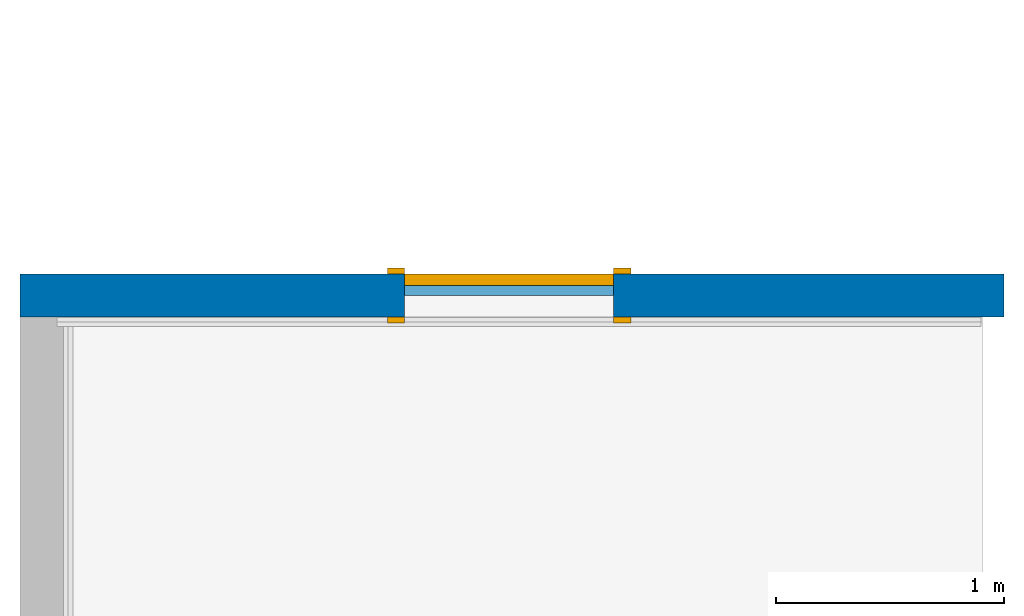
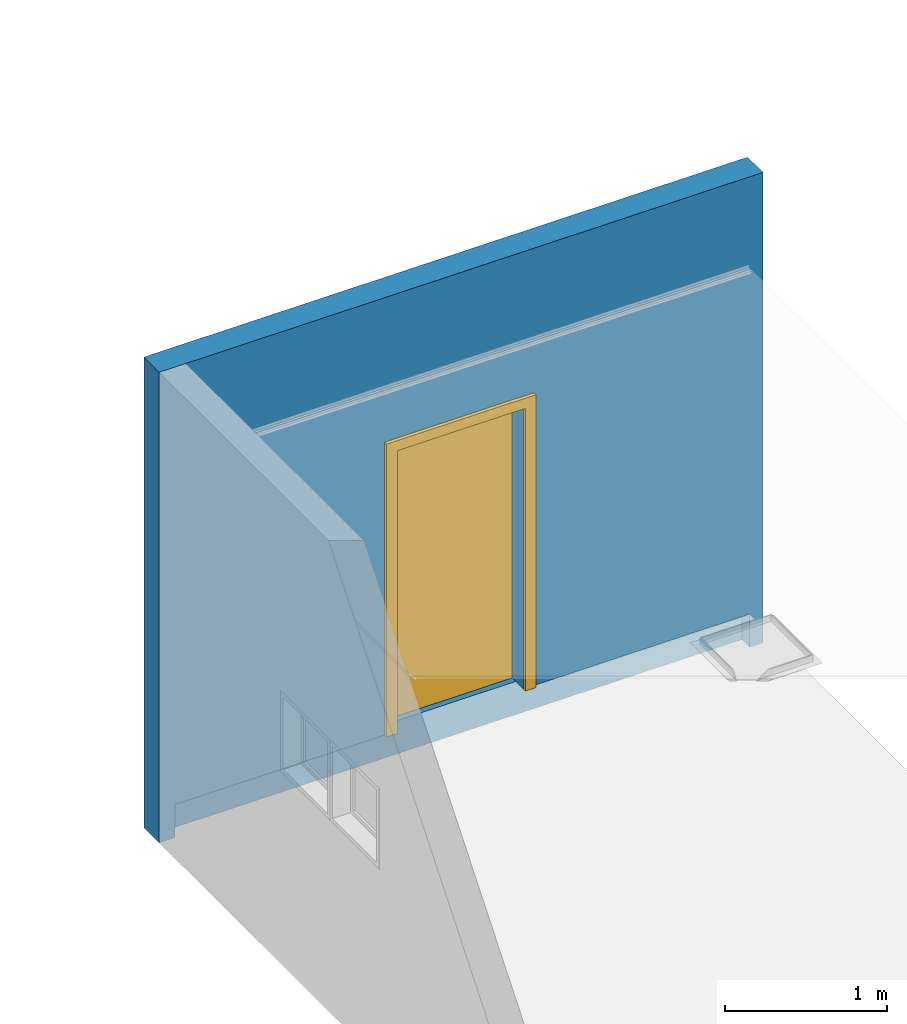
# One storey, part 2 of 5: 1 door, 1 wall, 1 opening.
"""IFC2X3 building model written with IfcOpenShell, lengths in millimetres."""

from ifc_helpers import new_model, entity, si_unit, converted_unit, derived_unit, direction, frame, frame_2d, origin, place, context, subcontext, project, spatial, polyline, rectangle, outline, extrude, faceted_brep, source, transform, mapped, material, material_list, layer, layer_set, type_object, type_shapes, element, fill, save


model = new_model("IFC2X3")

# Units and contexts
model_context = context("Model", 3, precision=0.01, world=origin(), true_north=direction((6.12303176911189e-17, 1.0)))
body_context = subcontext(model_context, "Body", "Model", "MODEL_VIEW")
ifc_project = project(units=[si_unit("LENGTHUNIT", "METRE", prefix="MILLI"), si_unit("AREAUNIT", "SQUARE_METRE"), si_unit("VOLUMEUNIT", "CUBIC_METRE"), converted_unit("PLANEANGLEUNIT", "DEGREE", entity("IfcRatioMeasure", 0.0174532925199433), si_unit("PLANEANGLEUNIT", "RADIAN"), dimensions=[0, 0, 0, 0, 0, 0, 0]), si_unit("MASSUNIT", "GRAM", prefix="KILO"), derived_unit("MASSDENSITYUNIT", [(si_unit("MASSUNIT", "GRAM", prefix="KILO"), 1), (si_unit("LENGTHUNIT", "METRE"), -3)]), si_unit("TIMEUNIT", "SECOND"), si_unit("FREQUENCYUNIT", "HERTZ"), si_unit("THERMODYNAMICTEMPERATUREUNIT", "DEGREE_CELSIUS"), derived_unit("THERMALTRANSMITTANCEUNIT", [(si_unit("MASSUNIT", "GRAM", prefix="KILO"), 1), (si_unit("THERMODYNAMICTEMPERATUREUNIT", "KELVIN"), -1), (si_unit("TIMEUNIT", "SECOND"), -3)]), derived_unit("VOLUMETRICFLOWRATEUNIT", [(si_unit("LENGTHUNIT", "METRE"), 3), (si_unit("TIMEUNIT", "SECOND"), -1)]), si_unit("ELECTRICCURRENTUNIT", "AMPERE"), si_unit("ELECTRICVOLTAGEUNIT", "VOLT"), si_unit("POWERUNIT", "WATT"), si_unit("FORCEUNIT", "NEWTON", prefix="KILO"), si_unit("ILLUMINANCEUNIT", "LUX"), si_unit("LUMINOUSFLUXUNIT", "LUMEN"), si_unit("LUMINOUSINTENSITYUNIT", "CANDELA"), derived_unit("USERDEFINED", [(si_unit("MASSUNIT", "GRAM", prefix="KILO"), -1), (si_unit("LENGTHUNIT", "METRE"), -2), (si_unit("TIMEUNIT", "SECOND"), 3), (si_unit("LUMINOUSFLUXUNIT", "LUMEN"), 1)]), derived_unit("LINEARVELOCITYUNIT", [(si_unit("LENGTHUNIT", "METRE"), 1), (si_unit("TIMEUNIT", "SECOND"), -1)]), si_unit("PRESSUREUNIT", "PASCAL"), derived_unit("USERDEFINED", [(si_unit("LENGTHUNIT", "METRE"), -2), (si_unit("MASSUNIT", "GRAM", prefix="KILO"), 1), (si_unit("TIMEUNIT", "SECOND"), -2)])], contexts=[model_context])

# Site, building, storey
site_placement = place(None, origin())
site = spatial("IfcSite", under=ifc_project, at=site_placement, CompositionType="ELEMENT")
building_placement = place(site_placement, origin())
building = spatial("IfcBuilding", under=site, at=building_placement, CompositionType="ELEMENT")
storey_placement = place(building_placement, origin())
storey = spatial("IfcBuildingStorey", under=building, at=storey_placement, Name="Base Level", CompositionType="ELEMENT", Elevation=0.0)

# Wall, opening, door
ifc_material_1 = material(Name="np_Plastered")
ifc_layer = layer(ifc_material_1, 190.0)
ifc_layer_set = layer_set([ifc_layer], Name="Basic Wall:190mm BLOCK- plastered")
wall_type = type_object("IfcWallType", Name="Basic Wall:190mm BLOCK- plastered", PredefinedType="STANDARD", material=ifc_layer_set)
wall_placement = place(building_placement, frame((105252.734552934, 6312.91938039376, -250.0)))
wall = element("IfcWall", 1, at=wall_placement, inside=storey, type_object=wall_type, material=ifc_material_1, Name="Basic Wall:190mm BLOCK- plastered:2488", ObjectType="Basic Wall:190mm BLOCK- plastered", context=body_context, shape_type="Brep", body=[
    faceted_brep([(4309.0, -95.0, 0.0), (4309.0, -95.0, 3550.0), (190.0, -95.0, 3550.0), (0.0, -95.0, 3550.0), (0.0, -95.0, 0.0), (114.0, -95.0, 0.0), (114.0, -95.0, 250.0), (1684.5000000001, -95.0, 250.0), (1684.5000000001, -95.0, 2384.0), (2599.5000000001, -95.0, 2384.0), (2599.5000000001, -95.0, 250.0), (4214.0, -95.0, 250.0), (4214.0, -95.0, 0.0), (4309.0, 95.0, 0.0), (0.0, 95.0, 0.0), (0.0, 95.0, 3550.0), (4309.0, 95.0, 3550.0), (1684.5000000001, 95.0, 250.0), (2599.5000000001, 95.0, 250.0), (2599.5000000001, 95.0, 2384.0), (1684.5000000001, 95.0, 2384.0), (4214.0, 0.0, 0.0), (114.0, 0.0, 0.0), (1684.5000000001, 0.0, 250.0), (2599.5000000001, 0.0, 250.0), (4214.0, 0.0, 250.0), (114.0, 0.0, 250.0)], [[[0, 1, 2, 3, 4, 5, 6, 7, 8, 9, 10, 11, 12]], [[13, 14, 15, 16], [17, 18, 19, 20]], [[14, 13, 0, 12, 21, 22, 5, 4]], [[1, 0, 13, 16]], [[3, 2, 1, 16, 15]], [[18, 17, 23, 24]], [[19, 18, 24, 10, 9]], [[20, 19, 9, 8]], [[17, 20, 8, 7, 23]], [[24, 25, 11, 10]], [[26, 22, 21, 25, 24, 23]], [[22, 26, 6, 5]], [[25, 21, 12, 11]], [[4, 3, 15, 14]], [[26, 23, 7, 6]]]),
])
opening_placement = place(wall_placement, frame((1684.50000000011, -95.0, 250.0)))
opening = element("IfcOpeningElement", 2, at=opening_placement, cuts=wall, Name="M_Single-Flush:0915 x 2134mm:2496:1", ObjectType="Opening", context=body_context, shape_type="SweptSolid", body=[
    extrude(rectangle(XDim=915.0, YDim=2134.0, at=frame_2d((1067.0, 457.5), x_axis=(0.0, 1.0))), frame((0.0, 0.0, 0.0), z_axis=(0.0, 1.0, 0.0), x_axis=(0.0, 0.0, 1.0)), (0.0, 0.0, 1.0), 190.0),
])
ifc_material_2 = material(Name="Door - Frame")
ifc_material_3 = material(Name="Door - Panel")
ifc_material_list_1 = material_list([ifc_material_2, ifc_material_3])
ifc_material_list_2 = material_list([ifc_material_2, ifc_material_3])
door_style = type_object("IfcDoorStyle", Name="0915 x 2134mm", ConstructionType="NOTDEFINED", OperationType="SINGLE_SWING_RIGHT", ParameterTakesPrecedence=False, Sizeable=False, material=ifc_material_list_2)
shared_shape = source(origin(), body_context, "Body", "SweptSolid", [
    extrude(outline(polyline([(-533.5, -1124.0), (533.5, -1124.0), (533.5, 1086.0), (457.5, 1086.0), (457.5, -1048.0), (-457.5, -1048.0), (-457.5, 1086.0), (-533.5, 1086.0), (-533.5, -1124.0)])), frame((457.500000000001, 190.0, 1086.0), z_axis=(0.0, 1.0, 0.0), x_axis=(1.0, 0.0, 0.0)), (0.0, 0.0, 1.0), 24.9999999999945),
    extrude(outline(polyline([(-1124.0, -533.499999999997), (1086.0, -533.499999999997), (1086.0, -457.500000000007), (-1048.0, -457.500000000007), (-1048.0, 457.500000000002), (1086.0, 457.500000000002), (1086.0, 533.500000000003), (-1124.0, 533.500000000003), (-1124.0, -533.499999999997)])), frame((457.500000000003, -25.0, 1086.0), z_axis=(0.0, 1.0, 0.0), x_axis=(0.0, 0.0, -1.0)), (0.0, 0.0, 1.0), 25.0000000000056),
    extrude(rectangle(XDim=51.0, YDim=915.0, at=frame_2d((5.32907051820075e-15, 0.0), x_axis=(1.0, 0.0))), frame((457.5, 164.499999999999, 0.0), z_axis=(0.0, 0.0, 1.0), x_axis=(0.0, 1.0, 0.0)), (0.0, 0.0, 1.0), 2134.0),
])
type_shapes(door_style, [shared_shape])
door_placement = place(opening_placement, origin())
door = element("IfcDoor", 3, at=door_placement, inside=storey, type_object=door_style, material=ifc_material_list_1, Name="M_Single-Flush:0915 x 2134mm:2496", ObjectType="M_Single-Flush:0915 x 2134mm", OverallHeight=2134.0, OverallWidth=915.0, context=body_context, shape_type="MappedRepresentation", body=[
    mapped(shared_shape, transform((0.0, 0.0, 0.0), scale=1.0)),
])
fill(opening, door)

save(model, "model.ifc")
